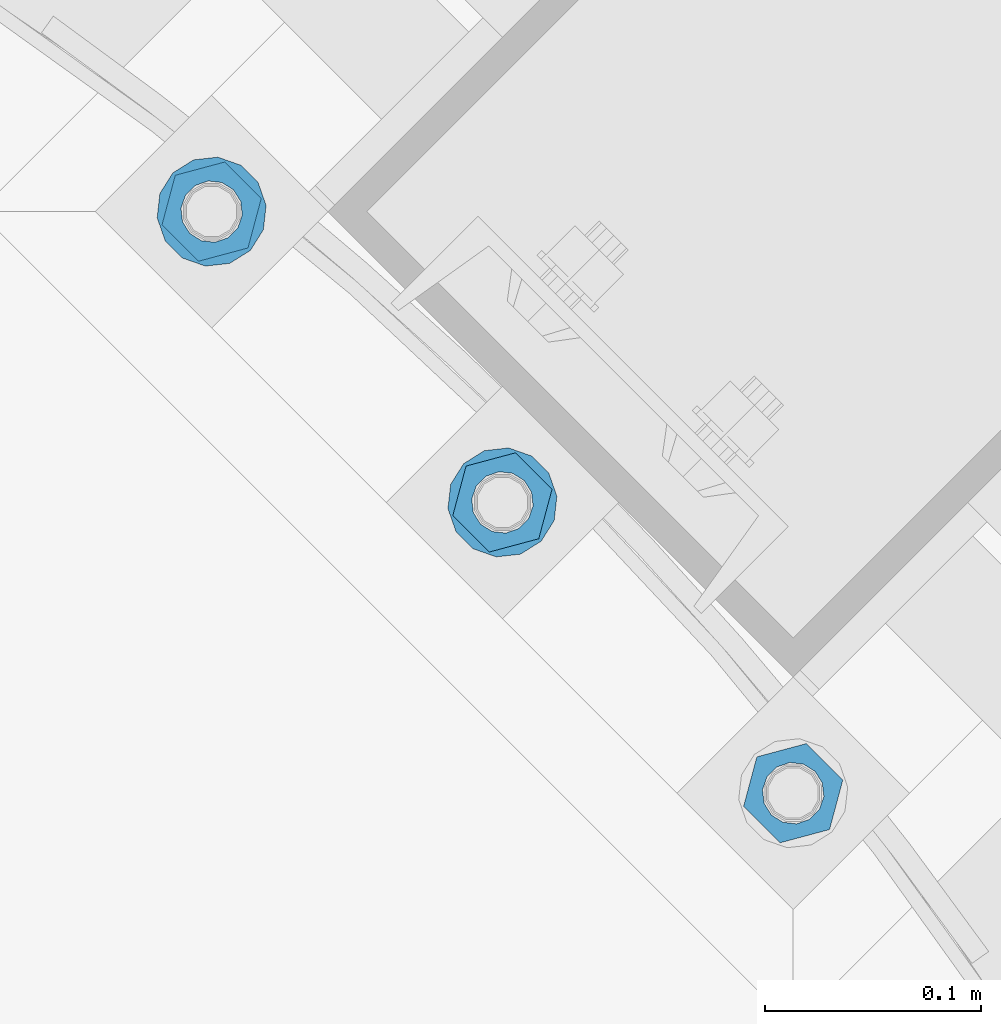
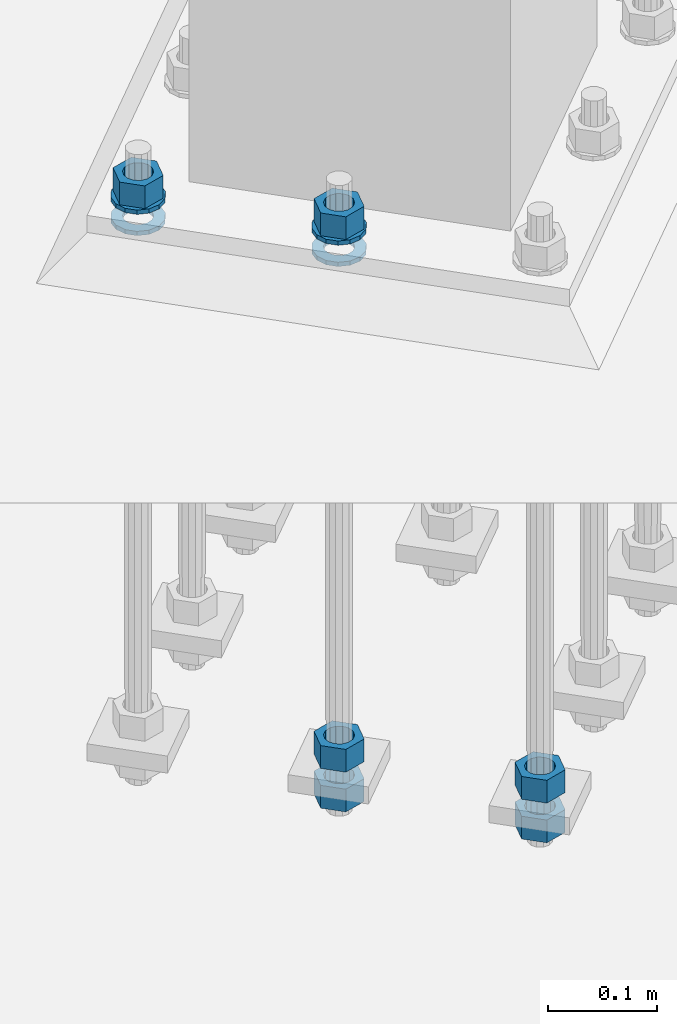
# One storey, part 874 of 1876: 10 columns, 1 element without a shape of its own.
"""IFC2X3 building model written with IfcOpenShell, lengths in millimetres."""

from ifc_helpers import new_model, si_unit, frame, origin_with_axes, place, context, subcontext, project, spatial, faceted_brep, material, type_object, element, aggregate, save


model = new_model("IFC2X3")

# Units and contexts
model_context = context("Model", 3, precision=1e-05, world=origin_with_axes())
body_context = subcontext(model_context, "Body", "Model", "MODEL_VIEW")
ifc_project = project(units=[si_unit("LENGTHUNIT", "METRE", prefix="MILLI"), si_unit("AREAUNIT", "SQUARE_METRE"), si_unit("VOLUMEUNIT", "CUBIC_METRE"), si_unit("MASSUNIT", "GRAM", prefix="KILO"), si_unit("TIMEUNIT", "SECOND"), si_unit("PLANEANGLEUNIT", "RADIAN"), si_unit("SOLIDANGLEUNIT", "STERADIAN"), si_unit("THERMODYNAMICTEMPERATUREUNIT", "DEGREE_CELSIUS"), si_unit("LUMINOUSINTENSITYUNIT", "LUMEN")], contexts=[model_context])

# Site, building, storey
site_placement = place(None, origin_with_axes())
site = spatial("IfcSite", under=ifc_project, at=site_placement, CompositionType="ELEMENT")
building_placement = place(site_placement, origin_with_axes())
building = spatial("IfcBuilding", under=site, at=building_placement, Name="Undefined", CompositionType="ELEMENT")
storey_placement = place(building_placement, origin_with_axes())
storey = spatial("IfcBuildingStorey", under=building, at=storey_placement, Name="Undefined", CompositionType="ELEMENT", Elevation=0.0)

# Assembly, columns
assembly_placement = place(storey_placement, origin_with_axes())
assembly = element("IfcElementAssembly", 1, at=assembly_placement, inside=storey, Name="TEMPLATE", AssemblyPlace="NOTDEFINED", PredefinedType="RIGID_FRAME")
ifc_material_1 = material(Name="STEEL/A563")
column_type_1 = type_object("IfcColumnType", Name="1_HEAVY_HEX_NUT", PredefinedType="NOTDEFINED")
column_1_placement = place(assembly_placement, frame((6580.27489085663, -12459.7327927759, -508.0), z_axis=(0.707106781186548, 0.707106781186547, 0.0), x_axis=(0.0, 0.0, -1.0)))
column_1 = element("IfcColumn", 2, at=column_1_placement, type_object=column_type_1, material=ifc_material_1, Name="NUT", ObjectType="1_HEAVY_HEX_NUT", context=body_context, shape_type="Brep", body=[
    faceted_brep([(0.0, -23.8099994659442, 9.09494701772928e-13), (0.0, -11.9099998474121, -20.6200008392352), (25.4, -11.9099998474157, -20.6200008392361), (25.4, -23.8099994659478, 0.0), (0.0, 11.9099998474157, -20.620000839237), (25.4, 11.9099998474121, -20.620000839237), (0.0, 23.8099994659478, 9.09494701772928e-13), (25.4, 23.8099994659442, 0.0), (0.0, 11.9099998474157, 20.620000839237), (25.4, 11.9099998474121, 20.620000839237), (0.0, -11.9099998474121, 20.6200008392389), (25.4, -11.9099998474157, 20.6200008392379), (0.0, 1.81898940354586e-12, 14.2899999618567), (0.0, 6.20019861543915, 12.8748450879584), (25.4, 6.20019861543733, 12.8748450879593), (25.4, 0.0, 14.2899999618558), (0.0, 11.1723718546473, 8.90966924477925), (25.4, 11.1723718546436, 8.90966924477925), (0.0, 13.9317198278914, 3.17982413774916), (25.4, 13.9317198278877, 3.17982413775007), (0.0, 13.9317198278914, -3.17982413774644), (25.4, 13.9317198278895, -3.17982413774735), (0.0, 11.1723718546473, -8.90966924477834), (25.4, 11.1723718546455, -8.90966924477925), (0.0, 6.20019861544279, -12.8748450879575), (25.4, 6.20019861543915, -12.8748450879584), (0.0, 3.63797880709171e-12, -14.2899999618548), (25.4, -3.63797880709171e-12, -14.2899999618548), (0.0, -6.20019861543733, -12.8748450879566), (25.4, -6.20019861544097, -12.8748450879584), (0.0, -11.1723718546455, -8.90966924477743), (25.4, -11.1723718546473, -8.90966924477834), (0.0, -13.9317198278877, -3.17982413774735), (25.4, -13.9317198278914, -3.17982413774826), (0.0, -13.9317198278895, 3.17982413774735), (25.4, -13.9317198278914, 3.17982413774826), (0.0, -11.1723718546455, 8.90966924477925), (25.4, -11.1723718546473, 8.90966924478016), (0.0, -6.20019861543915, 12.8748450879593), (25.4, -6.20019861544279, 12.8748450879593)], [[[0, 1, 2, 3]], [[1, 4, 5, 2]], [[4, 6, 7, 5]], [[6, 8, 9, 7]], [[8, 10, 11, 9]], [[10, 0, 3, 11]], [[12, 13, 14, 15]], [[13, 16, 17, 14]], [[16, 18, 19, 17]], [[18, 20, 21, 19]], [[20, 22, 23, 21]], [[22, 24, 25, 23]], [[24, 26, 27, 25]], [[26, 28, 29, 27]], [[28, 30, 31, 29]], [[30, 32, 33, 31]], [[32, 34, 35, 33]], [[34, 36, 37, 35]], [[36, 38, 39, 37]], [[38, 12, 15, 39]], [[5, 7, 9, 11, 3, 2], [17, 19, 21, 23, 25, 27, 29, 31, 33, 35, 37, 39, 15, 14]], [[10, 8, 6, 4, 1, 0], [38, 36, 34, 32, 30, 28, 26, 24, 22, 20, 18, 16, 13, 12]]]),
])
column_2_placement = place(assembly_placement, frame((6580.27489085663, -12459.7327927759, -552.45), z_axis=(0.707106781186548, 0.707106781186547, 0.0), x_axis=(0.0, 0.0, -1.0)))
column_2 = element("IfcColumn", 3, at=column_2_placement, type_object=column_type_1, material=ifc_material_1, Name="NUT", ObjectType="1_HEAVY_HEX_NUT", context=body_context, shape_type="Brep", body=[
    faceted_brep([(0.0, -23.8099994659442, 9.09494701772928e-13), (0.0, -11.9099998474121, -20.6200008392352), (25.4, -11.9099998474157, -20.6200008392361), (25.4, -23.8099994659478, 0.0), (0.0, 11.9099998474157, -20.620000839237), (25.4, 11.9099998474121, -20.620000839237), (0.0, 23.8099994659478, 9.09494701772928e-13), (25.4, 23.8099994659442, 0.0), (0.0, 11.9099998474157, 20.620000839237), (25.4, 11.9099998474121, 20.620000839237), (0.0, -11.9099998474121, 20.6200008392389), (25.4, -11.9099998474157, 20.6200008392379), (0.0, 1.81898940354586e-12, 14.2899999618567), (0.0, 6.20019861543915, 12.8748450879584), (25.4, 6.20019861543733, 12.8748450879593), (25.4, 0.0, 14.2899999618558), (0.0, 11.1723718546473, 8.90966924477925), (25.4, 11.1723718546436, 8.90966924477925), (0.0, 13.9317198278914, 3.17982413774916), (25.4, 13.9317198278877, 3.17982413775007), (0.0, 13.9317198278914, -3.17982413774644), (25.4, 13.9317198278895, -3.17982413774735), (0.0, 11.1723718546473, -8.90966924477834), (25.4, 11.1723718546455, -8.90966924477925), (0.0, 6.20019861544279, -12.8748450879575), (25.4, 6.20019861543915, -12.8748450879584), (0.0, 3.63797880709171e-12, -14.2899999618548), (25.4, -3.63797880709171e-12, -14.2899999618548), (0.0, -6.20019861543733, -12.8748450879566), (25.4, -6.20019861544097, -12.8748450879584), (0.0, -11.1723718546455, -8.90966924477743), (25.4, -11.1723718546473, -8.90966924477834), (0.0, -13.9317198278877, -3.17982413774735), (25.4, -13.9317198278914, -3.17982413774826), (0.0, -13.9317198278895, 3.17982413774735), (25.4, -13.9317198278914, 3.17982413774826), (0.0, -11.1723718546455, 8.90966924477925), (25.4, -11.1723718546473, 8.90966924478016), (0.0, -6.20019861543915, 12.8748450879593), (25.4, -6.20019861544279, 12.8748450879593)], [[[0, 1, 2, 3]], [[1, 4, 5, 2]], [[4, 6, 7, 5]], [[6, 8, 9, 7]], [[8, 10, 11, 9]], [[10, 0, 3, 11]], [[12, 13, 14, 15]], [[13, 16, 17, 14]], [[16, 18, 19, 17]], [[18, 20, 21, 19]], [[20, 22, 23, 21]], [[22, 24, 25, 23]], [[24, 26, 27, 25]], [[26, 28, 29, 27]], [[28, 30, 31, 29]], [[30, 32, 33, 31]], [[32, 34, 35, 33]], [[34, 36, 37, 35]], [[36, 38, 39, 37]], [[38, 12, 15, 39]], [[5, 7, 9, 11, 3, 2], [17, 19, 21, 23, 25, 27, 29, 31, 33, 35, 37, 39, 15, 14]], [[10, 8, 6, 4, 1, 0], [38, 36, 34, 32, 30, 28, 26, 24, 22, 20, 18, 16, 13, 12]]]),
])
column_3_placement = place(assembly_placement, frame((6445.57104904047, -12325.0289509597, 87.3125), z_axis=(0.707106781186548, 0.707106781186547, 0.0), x_axis=(0.0, 0.0, -1.0)))
column_3 = element("IfcColumn", 4, at=column_3_placement, type_object=column_type_1, material=ifc_material_1, Name="NUT", ObjectType="1_HEAVY_HEX_NUT", context=body_context, shape_type="Brep", body=[
    faceted_brep([(0.0, -23.8099994659442, 9.09494701772928e-13), (0.0, -11.9099998474121, -20.6200008392352), (25.4, -11.9099998474157, -20.6200008392361), (25.4, -23.8099994659478, 0.0), (0.0, 11.9099998474157, -20.620000839237), (25.4, 11.9099998474121, -20.620000839237), (0.0, 23.8099994659478, 9.09494701772928e-13), (25.4, 23.8099994659442, 0.0), (0.0, 11.9099998474157, 20.620000839237), (25.4, 11.9099998474121, 20.620000839237), (0.0, -11.9099998474121, 20.6200008392389), (25.4, -11.9099998474157, 20.6200008392379), (0.0, 1.81898940354586e-12, 14.2899999618567), (0.0, 6.20019861543915, 12.8748450879584), (25.4, 6.20019861543733, 12.8748450879593), (25.4, 0.0, 14.2899999618558), (0.0, 11.1723718546473, 8.90966924477925), (25.4, 11.1723718546436, 8.90966924477925), (0.0, 13.9317198278914, 3.17982413774916), (25.4, 13.9317198278877, 3.17982413775007), (0.0, 13.9317198278914, -3.17982413774644), (25.4, 13.9317198278895, -3.17982413774735), (0.0, 11.1723718546473, -8.90966924477834), (25.4, 11.1723718546455, -8.90966924477925), (0.0, 6.20019861544279, -12.8748450879575), (25.4, 6.20019861543915, -12.8748450879584), (0.0, 3.63797880709171e-12, -14.2899999618548), (25.4, -3.63797880709171e-12, -14.2899999618548), (0.0, -6.20019861543733, -12.8748450879566), (25.4, -6.20019861544097, -12.8748450879584), (0.0, -11.1723718546455, -8.90966924477743), (25.4, -11.1723718546473, -8.90966924477834), (0.0, -13.9317198278877, -3.17982413774735), (25.4, -13.9317198278914, -3.17982413774826), (0.0, -13.9317198278895, 3.17982413774735), (25.4, -13.9317198278914, 3.17982413774826), (0.0, -11.1723718546455, 8.90966924477925), (25.4, -11.1723718546473, 8.90966924478016), (0.0, -6.20019861543915, 12.8748450879593), (25.4, -6.20019861544279, 12.8748450879593)], [[[0, 1, 2, 3]], [[1, 4, 5, 2]], [[4, 6, 7, 5]], [[6, 8, 9, 7]], [[8, 10, 11, 9]], [[10, 0, 3, 11]], [[12, 13, 14, 15]], [[13, 16, 17, 14]], [[16, 18, 19, 17]], [[18, 20, 21, 19]], [[20, 22, 23, 21]], [[22, 24, 25, 23]], [[24, 26, 27, 25]], [[26, 28, 29, 27]], [[28, 30, 31, 29]], [[30, 32, 33, 31]], [[32, 34, 35, 33]], [[34, 36, 37, 35]], [[36, 38, 39, 37]], [[38, 12, 15, 39]], [[5, 7, 9, 11, 3, 2], [17, 19, 21, 23, 25, 27, 29, 31, 33, 35, 37, 39, 15, 14]], [[10, 8, 6, 4, 1, 0], [38, 36, 34, 32, 30, 28, 26, 24, 22, 20, 18, 16, 13, 12]]]),
])
column_4_placement = place(assembly_placement, frame((6445.57104904047, -12325.0289509597, -508.0), z_axis=(0.707106781186548, 0.707106781186547, 0.0), x_axis=(0.0, 0.0, -1.0)))
column_4 = element("IfcColumn", 5, at=column_4_placement, type_object=column_type_1, material=ifc_material_1, Name="NUT", ObjectType="1_HEAVY_HEX_NUT", context=body_context, shape_type="Brep", body=[
    faceted_brep([(0.0, -23.8099994659442, 9.09494701772928e-13), (0.0, -11.9099998474121, -20.6200008392352), (25.4, -11.9099998474157, -20.6200008392361), (25.4, -23.8099994659478, 0.0), (0.0, 11.9099998474157, -20.620000839237), (25.4, 11.9099998474121, -20.620000839237), (0.0, 23.8099994659478, 9.09494701772928e-13), (25.4, 23.8099994659442, 0.0), (0.0, 11.9099998474157, 20.620000839237), (25.4, 11.9099998474121, 20.620000839237), (0.0, -11.9099998474121, 20.6200008392389), (25.4, -11.9099998474157, 20.6200008392379), (0.0, 1.81898940354586e-12, 14.2899999618567), (0.0, 6.20019861543915, 12.8748450879584), (25.4, 6.20019861543733, 12.8748450879593), (25.4, 0.0, 14.2899999618558), (0.0, 11.1723718546473, 8.90966924477925), (25.4, 11.1723718546436, 8.90966924477925), (0.0, 13.9317198278914, 3.17982413774916), (25.4, 13.9317198278877, 3.17982413775007), (0.0, 13.9317198278914, -3.17982413774644), (25.4, 13.9317198278895, -3.17982413774735), (0.0, 11.1723718546473, -8.90966924477834), (25.4, 11.1723718546455, -8.90966924477925), (0.0, 6.20019861544279, -12.8748450879575), (25.4, 6.20019861543915, -12.8748450879584), (0.0, 3.63797880709171e-12, -14.2899999618548), (25.4, -3.63797880709171e-12, -14.2899999618548), (0.0, -6.20019861543733, -12.8748450879566), (25.4, -6.20019861544097, -12.8748450879584), (0.0, -11.1723718546455, -8.90966924477743), (25.4, -11.1723718546473, -8.90966924477834), (0.0, -13.9317198278877, -3.17982413774735), (25.4, -13.9317198278914, -3.17982413774826), (0.0, -13.9317198278895, 3.17982413774735), (25.4, -13.9317198278914, 3.17982413774826), (0.0, -11.1723718546455, 8.90966924477925), (25.4, -11.1723718546473, 8.90966924478016), (0.0, -6.20019861543915, 12.8748450879593), (25.4, -6.20019861544279, 12.8748450879593)], [[[0, 1, 2, 3]], [[1, 4, 5, 2]], [[4, 6, 7, 5]], [[6, 8, 9, 7]], [[8, 10, 11, 9]], [[10, 0, 3, 11]], [[12, 13, 14, 15]], [[13, 16, 17, 14]], [[16, 18, 19, 17]], [[18, 20, 21, 19]], [[20, 22, 23, 21]], [[22, 24, 25, 23]], [[24, 26, 27, 25]], [[26, 28, 29, 27]], [[28, 30, 31, 29]], [[30, 32, 33, 31]], [[32, 34, 35, 33]], [[34, 36, 37, 35]], [[36, 38, 39, 37]], [[38, 12, 15, 39]], [[5, 7, 9, 11, 3, 2], [17, 19, 21, 23, 25, 27, 29, 31, 33, 35, 37, 39, 15, 14]], [[10, 8, 6, 4, 1, 0], [38, 36, 34, 32, 30, 28, 26, 24, 22, 20, 18, 16, 13, 12]]]),
])
column_5_placement = place(assembly_placement, frame((6445.57104904047, -12325.0289509597, -552.45), z_axis=(0.707106781186548, 0.707106781186547, 0.0), x_axis=(0.0, 0.0, -1.0)))
column_5 = element("IfcColumn", 6, at=column_5_placement, type_object=column_type_1, material=ifc_material_1, Name="NUT", ObjectType="1_HEAVY_HEX_NUT", context=body_context, shape_type="Brep", body=[
    faceted_brep([(0.0, -23.8099994659442, 9.09494701772928e-13), (0.0, -11.9099998474121, -20.6200008392352), (25.4, -11.9099998474157, -20.6200008392361), (25.4, -23.8099994659478, 0.0), (0.0, 11.9099998474157, -20.620000839237), (25.4, 11.9099998474121, -20.620000839237), (0.0, 23.8099994659478, 9.09494701772928e-13), (25.4, 23.8099994659442, 0.0), (0.0, 11.9099998474157, 20.620000839237), (25.4, 11.9099998474121, 20.620000839237), (0.0, -11.9099998474121, 20.6200008392389), (25.4, -11.9099998474157, 20.6200008392379), (0.0, 1.81898940354586e-12, 14.2899999618567), (0.0, 6.20019861543915, 12.8748450879584), (25.4, 6.20019861543733, 12.8748450879593), (25.4, 0.0, 14.2899999618558), (0.0, 11.1723718546473, 8.90966924477925), (25.4, 11.1723718546436, 8.90966924477925), (0.0, 13.9317198278914, 3.17982413774916), (25.4, 13.9317198278877, 3.17982413775007), (0.0, 13.9317198278914, -3.17982413774644), (25.4, 13.9317198278895, -3.17982413774735), (0.0, 11.1723718546473, -8.90966924477834), (25.4, 11.1723718546455, -8.90966924477925), (0.0, 6.20019861544279, -12.8748450879575), (25.4, 6.20019861543915, -12.8748450879584), (0.0, 3.63797880709171e-12, -14.2899999618548), (25.4, -3.63797880709171e-12, -14.2899999618548), (0.0, -6.20019861543733, -12.8748450879566), (25.4, -6.20019861544097, -12.8748450879584), (0.0, -11.1723718546455, -8.90966924477743), (25.4, -11.1723718546473, -8.90966924477834), (0.0, -13.9317198278877, -3.17982413774735), (25.4, -13.9317198278914, -3.17982413774826), (0.0, -13.9317198278895, 3.17982413774735), (25.4, -13.9317198278914, 3.17982413774826), (0.0, -11.1723718546455, 8.90966924477925), (25.4, -11.1723718546473, 8.90966924478016), (0.0, -6.20019861543915, 12.8748450879593), (25.4, -6.20019861544279, 12.8748450879593)], [[[0, 1, 2, 3]], [[1, 4, 5, 2]], [[4, 6, 7, 5]], [[6, 8, 9, 7]], [[8, 10, 11, 9]], [[10, 0, 3, 11]], [[12, 13, 14, 15]], [[13, 16, 17, 14]], [[16, 18, 19, 17]], [[18, 20, 21, 19]], [[20, 22, 23, 21]], [[22, 24, 25, 23]], [[24, 26, 27, 25]], [[26, 28, 29, 27]], [[28, 30, 31, 29]], [[30, 32, 33, 31]], [[32, 34, 35, 33]], [[34, 36, 37, 35]], [[36, 38, 39, 37]], [[38, 12, 15, 39]], [[5, 7, 9, 11, 3, 2], [17, 19, 21, 23, 25, 27, 29, 31, 33, 35, 37, 39, 15, 14]], [[10, 8, 6, 4, 1, 0], [38, 36, 34, 32, 30, 28, 26, 24, 22, 20, 18, 16, 13, 12]]]),
])
column_6_placement = place(assembly_placement, frame((6310.86720722432, -12190.3251091436, 87.3125), z_axis=(-0.707106781186547, -0.707106781186548, 0.0), x_axis=(0.0, 0.0, -1.0)))
column_6 = element("IfcColumn", 7, at=column_6_placement, type_object=column_type_1, material=ifc_material_1, Name="NUT", ObjectType="1_HEAVY_HEX_NUT", context=body_context, shape_type="Brep", body=[
    faceted_brep([(0.0, -23.8099994659442, 9.09494701772928e-13), (0.0, -11.9099998474121, -20.6200008392352), (25.4, -11.9099998474157, -20.6200008392361), (25.4, -23.8099994659478, 0.0), (0.0, 11.9099998474157, -20.620000839237), (25.4, 11.9099998474121, -20.620000839237), (0.0, 23.8099994659478, 9.09494701772928e-13), (25.4, 23.8099994659442, 0.0), (0.0, 11.9099998474157, 20.620000839237), (25.4, 11.9099998474121, 20.620000839237), (0.0, -11.9099998474121, 20.6200008392389), (25.4, -11.9099998474157, 20.6200008392379), (0.0, 1.81898940354586e-12, 14.2899999618567), (0.0, 6.20019861543915, 12.8748450879584), (25.4, 6.20019861543733, 12.8748450879593), (25.4, 0.0, 14.2899999618558), (0.0, 11.1723718546473, 8.90966924477925), (25.4, 11.1723718546436, 8.90966924477925), (0.0, 13.9317198278914, 3.17982413774916), (25.4, 13.9317198278877, 3.17982413775007), (0.0, 13.9317198278914, -3.17982413774644), (25.4, 13.9317198278895, -3.17982413774735), (0.0, 11.1723718546473, -8.90966924477834), (25.4, 11.1723718546455, -8.90966924477925), (0.0, 6.20019861544279, -12.8748450879575), (25.4, 6.20019861543915, -12.8748450879584), (0.0, 3.63797880709171e-12, -14.2899999618548), (25.4, -3.63797880709171e-12, -14.2899999618548), (0.0, -6.20019861543733, -12.8748450879566), (25.4, -6.20019861544097, -12.8748450879584), (0.0, -11.1723718546455, -8.90966924477743), (25.4, -11.1723718546473, -8.90966924477834), (0.0, -13.9317198278877, -3.17982413774735), (25.4, -13.9317198278914, -3.17982413774826), (0.0, -13.9317198278895, 3.17982413774735), (25.4, -13.9317198278914, 3.17982413774826), (0.0, -11.1723718546455, 8.90966924477925), (25.4, -11.1723718546473, 8.90966924478016), (0.0, -6.20019861543915, 12.8748450879593), (25.4, -6.20019861544279, 12.8748450879593)], [[[0, 1, 2, 3]], [[1, 4, 5, 2]], [[4, 6, 7, 5]], [[6, 8, 9, 7]], [[8, 10, 11, 9]], [[10, 0, 3, 11]], [[12, 13, 14, 15]], [[13, 16, 17, 14]], [[16, 18, 19, 17]], [[18, 20, 21, 19]], [[20, 22, 23, 21]], [[22, 24, 25, 23]], [[24, 26, 27, 25]], [[26, 28, 29, 27]], [[28, 30, 31, 29]], [[30, 32, 33, 31]], [[32, 34, 35, 33]], [[34, 36, 37, 35]], [[36, 38, 39, 37]], [[38, 12, 15, 39]], [[5, 7, 9, 11, 3, 2], [17, 19, 21, 23, 25, 27, 29, 31, 33, 35, 37, 39, 15, 14]], [[10, 8, 6, 4, 1, 0], [38, 36, 34, 32, 30, 28, 26, 24, 22, 20, 18, 16, 13, 12]]]),
])
ifc_material_2 = material(Name="STEEL/F436")
column_type_2 = type_object("IfcColumnType", Name="1_WASHER", PredefinedType="NOTDEFINED")
column_7_placement = place(assembly_placement, frame((6445.57104904047, -12325.0289509597, 38.1), z_axis=(0.707106781186548, 0.707106781186547, 0.0), x_axis=(0.0, 0.0, -1.0)))
column_7 = element("IfcColumn", 8, at=column_7_placement, type_object=column_type_2, material=ifc_material_2, Name="WASHER", ObjectType="1_WASHER", context=body_context, shape_type="Brep", body=[
    faceted_brep([(0.0, -25.3999996185375, 0.0), (0.0, -22.8846089010331, -11.0206468080742), (4.7625, -22.8846089010331, -11.0206468080742), (4.7625, -25.3999996185375, 0.0), (0.0, -15.8366407293743, -19.8585193564477), (4.7625, -15.8366407293743, -19.8585193564477), (0.0, -5.65203163760816, -24.7631685975166), (4.7625, -5.65203163760816, -24.7631685975166), (0.0, 5.65203163760452, -24.7631685975166), (4.7625, 5.65203163760452, -24.7631685975166), (0.0, 15.8366407293706, -19.858519356445), (4.7625, 15.8366407293706, -19.858519356445), (0.0, 22.8846089010331, -11.0206468080733), (4.7625, 22.8846089010331, -11.0206468080733), (0.0, 25.3999996185339, 9.09494701772928e-13), (4.7625, 25.3999996185339, 9.09494701772928e-13), (0.0, 22.8846089010331, 11.0206468080751), (4.7625, 22.8846089010331, 11.0206468080751), (0.0, 15.8366407293706, 19.8585193564486), (4.7625, 15.8366407293706, 19.8585193564486), (0.0, 5.65203163760452, 24.7631685975175), (4.7625, 5.65203163760452, 24.7631685975175), (0.0, -5.65203163760816, 24.7631685975175), (4.7625, -5.65203163760816, 24.7631685975175), (0.0, -15.8366407293724, 19.8585193564459), (4.7625, -15.8366407293724, 19.8585193564459), (0.0, -22.8846089010367, 11.0206468080751), (4.7625, -22.8846089010367, 11.0206468080751), (0.0, 1.81898940354586e-12, 14.2899999618567), (0.0, 6.20019861543915, 12.8748450879584), (4.7625, 6.20019861543733, 12.8748450879593), (4.7625, 0.0, 14.2899999618558), (0.0, 11.1723718546473, 8.90966924477925), (4.7625, 11.1723718546436, 8.90966924477925), (0.0, 13.9317198278914, 3.17982413774916), (4.7625, 13.9317198278877, 3.17982413775007), (0.0, 13.9317198278914, -3.17982413774644), (4.7625, 13.9317198278895, -3.17982413774735), (0.0, 11.1723718546473, -8.90966924477834), (4.7625, 11.1723718546455, -8.90966924477925), (0.0, 6.20019861544279, -12.8748450879575), (4.7625, 6.20019861543915, -12.8748450879584), (0.0, 3.63797880709171e-12, -14.2899999618548), (4.7625, -3.63797880709171e-12, -14.2899999618548), (0.0, -6.20019861543733, -12.8748450879566), (4.7625, -6.20019861544097, -12.8748450879584), (0.0, -11.1723718546455, -8.90966924477743), (4.7625, -11.1723718546473, -8.90966924477834), (0.0, -13.9317198278877, -3.17982413774735), (4.7625, -13.9317198278914, -3.17982413774826), (0.0, -13.9317198278895, 3.17982413774735), (4.7625, -13.9317198278914, 3.17982413774826), (0.0, -11.1723718546455, 8.90966924477925), (4.7625, -11.1723718546473, 8.90966924478016), (0.0, -6.20019861543915, 12.8748450879593), (4.7625, -6.20019861544279, 12.8748450879593)], [[[0, 1, 2, 3]], [[1, 4, 5, 2]], [[4, 6, 7, 5]], [[6, 8, 9, 7]], [[8, 10, 11, 9]], [[10, 12, 13, 11]], [[12, 14, 15, 13]], [[14, 16, 17, 15]], [[16, 18, 19, 17]], [[18, 20, 21, 19]], [[20, 22, 23, 21]], [[22, 24, 25, 23]], [[24, 26, 27, 25]], [[26, 0, 3, 27]], [[28, 29, 30, 31]], [[29, 32, 33, 30]], [[32, 34, 35, 33]], [[34, 36, 37, 35]], [[36, 38, 39, 37]], [[38, 40, 41, 39]], [[40, 42, 43, 41]], [[42, 44, 45, 43]], [[44, 46, 47, 45]], [[46, 48, 49, 47]], [[48, 50, 51, 49]], [[50, 52, 53, 51]], [[52, 54, 55, 53]], [[54, 28, 31, 55]], [[5, 7, 9, 11, 13, 15, 17, 19, 21, 23, 25, 27, 3, 2], [33, 35, 37, 39, 41, 43, 45, 47, 49, 51, 53, 55, 31, 30]], [[26, 24, 22, 20, 18, 16, 14, 12, 10, 8, 6, 4, 1, 0], [54, 52, 50, 48, 46, 44, 42, 40, 38, 36, 34, 32, 29, 28]]]),
])
column_8_placement = place(assembly_placement, frame((6445.57104904047, -12325.0289509597, 61.9125), z_axis=(0.707106781186548, 0.707106781186547, 0.0), x_axis=(0.0, 0.0, -1.0)))
column_8 = element("IfcColumn", 9, at=column_8_placement, type_object=column_type_2, material=ifc_material_2, Name="WASHER", ObjectType="1_WASHER", context=body_context, shape_type="Brep", body=[
    faceted_brep([(0.0, -25.3999996185375, 0.0), (0.0, -22.8846089010331, -11.0206468080742), (4.7625, -22.8846089010331, -11.0206468080742), (4.7625, -25.3999996185375, 0.0), (0.0, -15.8366407293743, -19.8585193564477), (4.7625, -15.8366407293743, -19.8585193564477), (0.0, -5.65203163760816, -24.7631685975166), (4.7625, -5.65203163760816, -24.7631685975166), (0.0, 5.65203163760452, -24.7631685975166), (4.7625, 5.65203163760452, -24.7631685975166), (0.0, 15.8366407293706, -19.858519356445), (4.7625, 15.8366407293706, -19.858519356445), (0.0, 22.8846089010331, -11.0206468080733), (4.7625, 22.8846089010331, -11.0206468080733), (0.0, 25.3999996185339, 9.09494701772928e-13), (4.7625, 25.3999996185339, 9.09494701772928e-13), (0.0, 22.8846089010331, 11.0206468080751), (4.7625, 22.8846089010331, 11.0206468080751), (0.0, 15.8366407293706, 19.8585193564486), (4.7625, 15.8366407293706, 19.8585193564486), (0.0, 5.65203163760452, 24.7631685975175), (4.7625, 5.65203163760452, 24.7631685975175), (0.0, -5.65203163760816, 24.7631685975175), (4.7625, -5.65203163760816, 24.7631685975175), (0.0, -15.8366407293724, 19.8585193564459), (4.7625, -15.8366407293724, 19.8585193564459), (0.0, -22.8846089010367, 11.0206468080751), (4.7625, -22.8846089010367, 11.0206468080751), (0.0, 1.81898940354586e-12, 14.2899999618567), (0.0, 6.20019861543915, 12.8748450879584), (4.7625, 6.20019861543733, 12.8748450879593), (4.7625, 0.0, 14.2899999618558), (0.0, 11.1723718546473, 8.90966924477925), (4.7625, 11.1723718546436, 8.90966924477925), (0.0, 13.9317198278914, 3.17982413774916), (4.7625, 13.9317198278877, 3.17982413775007), (0.0, 13.9317198278914, -3.17982413774644), (4.7625, 13.9317198278895, -3.17982413774735), (0.0, 11.1723718546473, -8.90966924477834), (4.7625, 11.1723718546455, -8.90966924477925), (0.0, 6.20019861544279, -12.8748450879575), (4.7625, 6.20019861543915, -12.8748450879584), (0.0, 3.63797880709171e-12, -14.2899999618548), (4.7625, -3.63797880709171e-12, -14.2899999618548), (0.0, -6.20019861543733, -12.8748450879566), (4.7625, -6.20019861544097, -12.8748450879584), (0.0, -11.1723718546455, -8.90966924477743), (4.7625, -11.1723718546473, -8.90966924477834), (0.0, -13.9317198278877, -3.17982413774735), (4.7625, -13.9317198278914, -3.17982413774826), (0.0, -13.9317198278895, 3.17982413774735), (4.7625, -13.9317198278914, 3.17982413774826), (0.0, -11.1723718546455, 8.90966924477925), (4.7625, -11.1723718546473, 8.90966924478016), (0.0, -6.20019861543915, 12.8748450879593), (4.7625, -6.20019861544279, 12.8748450879593)], [[[0, 1, 2, 3]], [[1, 4, 5, 2]], [[4, 6, 7, 5]], [[6, 8, 9, 7]], [[8, 10, 11, 9]], [[10, 12, 13, 11]], [[12, 14, 15, 13]], [[14, 16, 17, 15]], [[16, 18, 19, 17]], [[18, 20, 21, 19]], [[20, 22, 23, 21]], [[22, 24, 25, 23]], [[24, 26, 27, 25]], [[26, 0, 3, 27]], [[28, 29, 30, 31]], [[29, 32, 33, 30]], [[32, 34, 35, 33]], [[34, 36, 37, 35]], [[36, 38, 39, 37]], [[38, 40, 41, 39]], [[40, 42, 43, 41]], [[42, 44, 45, 43]], [[44, 46, 47, 45]], [[46, 48, 49, 47]], [[48, 50, 51, 49]], [[50, 52, 53, 51]], [[52, 54, 55, 53]], [[54, 28, 31, 55]], [[5, 7, 9, 11, 13, 15, 17, 19, 21, 23, 25, 27, 3, 2], [33, 35, 37, 39, 41, 43, 45, 47, 49, 51, 53, 55, 31, 30]], [[26, 24, 22, 20, 18, 16, 14, 12, 10, 8, 6, 4, 1, 0], [54, 52, 50, 48, 46, 44, 42, 40, 38, 36, 34, 32, 29, 28]]]),
])
column_9_placement = place(assembly_placement, frame((6310.86720722432, -12190.3251091436, 38.1), z_axis=(-0.707106781186547, -0.707106781186548, 0.0), x_axis=(0.0, 0.0, -1.0)))
column_9 = element("IfcColumn", 10, at=column_9_placement, type_object=column_type_2, material=ifc_material_2, Name="WASHER", ObjectType="1_WASHER", context=body_context, shape_type="Brep", body=[
    faceted_brep([(0.0, -25.3999996185375, 0.0), (0.0, -22.8846089010331, -11.0206468080742), (4.7625, -22.8846089010331, -11.0206468080742), (4.7625, -25.3999996185375, 0.0), (0.0, -15.8366407293743, -19.8585193564477), (4.7625, -15.8366407293743, -19.8585193564477), (0.0, -5.65203163760816, -24.7631685975166), (4.7625, -5.65203163760816, -24.7631685975166), (0.0, 5.65203163760452, -24.7631685975166), (4.7625, 5.65203163760452, -24.7631685975166), (0.0, 15.8366407293706, -19.858519356445), (4.7625, 15.8366407293706, -19.858519356445), (0.0, 22.8846089010331, -11.0206468080733), (4.7625, 22.8846089010331, -11.0206468080733), (0.0, 25.3999996185339, 9.09494701772928e-13), (4.7625, 25.3999996185339, 9.09494701772928e-13), (0.0, 22.8846089010331, 11.0206468080751), (4.7625, 22.8846089010331, 11.0206468080751), (0.0, 15.8366407293706, 19.8585193564486), (4.7625, 15.8366407293706, 19.8585193564486), (0.0, 5.65203163760452, 24.7631685975175), (4.7625, 5.65203163760452, 24.7631685975175), (0.0, -5.65203163760816, 24.7631685975175), (4.7625, -5.65203163760816, 24.7631685975175), (0.0, -15.8366407293724, 19.8585193564459), (4.7625, -15.8366407293724, 19.8585193564459), (0.0, -22.8846089010367, 11.0206468080751), (4.7625, -22.8846089010367, 11.0206468080751), (0.0, 1.81898940354586e-12, 14.2899999618567), (0.0, 6.20019861543915, 12.8748450879584), (4.7625, 6.20019861543733, 12.8748450879593), (4.7625, 0.0, 14.2899999618558), (0.0, 11.1723718546473, 8.90966924477925), (4.7625, 11.1723718546436, 8.90966924477925), (0.0, 13.9317198278914, 3.17982413774916), (4.7625, 13.9317198278877, 3.17982413775007), (0.0, 13.9317198278914, -3.17982413774644), (4.7625, 13.9317198278895, -3.17982413774735), (0.0, 11.1723718546473, -8.90966924477834), (4.7625, 11.1723718546455, -8.90966924477925), (0.0, 6.20019861544279, -12.8748450879575), (4.7625, 6.20019861543915, -12.8748450879584), (0.0, 3.63797880709171e-12, -14.2899999618548), (4.7625, -3.63797880709171e-12, -14.2899999618548), (0.0, -6.20019861543733, -12.8748450879566), (4.7625, -6.20019861544097, -12.8748450879584), (0.0, -11.1723718546455, -8.90966924477743), (4.7625, -11.1723718546473, -8.90966924477834), (0.0, -13.9317198278877, -3.17982413774735), (4.7625, -13.9317198278914, -3.17982413774826), (0.0, -13.9317198278895, 3.17982413774735), (4.7625, -13.9317198278914, 3.17982413774826), (0.0, -11.1723718546455, 8.90966924477925), (4.7625, -11.1723718546473, 8.90966924478016), (0.0, -6.20019861543915, 12.8748450879593), (4.7625, -6.20019861544279, 12.8748450879593)], [[[0, 1, 2, 3]], [[1, 4, 5, 2]], [[4, 6, 7, 5]], [[6, 8, 9, 7]], [[8, 10, 11, 9]], [[10, 12, 13, 11]], [[12, 14, 15, 13]], [[14, 16, 17, 15]], [[16, 18, 19, 17]], [[18, 20, 21, 19]], [[20, 22, 23, 21]], [[22, 24, 25, 23]], [[24, 26, 27, 25]], [[26, 0, 3, 27]], [[28, 29, 30, 31]], [[29, 32, 33, 30]], [[32, 34, 35, 33]], [[34, 36, 37, 35]], [[36, 38, 39, 37]], [[38, 40, 41, 39]], [[40, 42, 43, 41]], [[42, 44, 45, 43]], [[44, 46, 47, 45]], [[46, 48, 49, 47]], [[48, 50, 51, 49]], [[50, 52, 53, 51]], [[52, 54, 55, 53]], [[54, 28, 31, 55]], [[5, 7, 9, 11, 13, 15, 17, 19, 21, 23, 25, 27, 3, 2], [33, 35, 37, 39, 41, 43, 45, 47, 49, 51, 53, 55, 31, 30]], [[26, 24, 22, 20, 18, 16, 14, 12, 10, 8, 6, 4, 1, 0], [54, 52, 50, 48, 46, 44, 42, 40, 38, 36, 34, 32, 29, 28]]]),
])
column_10_placement = place(assembly_placement, frame((6310.86720722432, -12190.3251091436, 61.9125), z_axis=(-0.707106781186547, -0.707106781186548, 0.0), x_axis=(0.0, 0.0, -1.0)))
column_10 = element("IfcColumn", 11, at=column_10_placement, type_object=column_type_2, material=ifc_material_2, Name="WASHER", ObjectType="1_WASHER", context=body_context, shape_type="Brep", body=[
    faceted_brep([(0.0, -25.3999996185375, 0.0), (0.0, -22.8846089010331, -11.0206468080742), (4.7625, -22.8846089010331, -11.0206468080742), (4.7625, -25.3999996185375, 0.0), (0.0, -15.8366407293743, -19.8585193564477), (4.7625, -15.8366407293743, -19.8585193564477), (0.0, -5.65203163760816, -24.7631685975166), (4.7625, -5.65203163760816, -24.7631685975166), (0.0, 5.65203163760452, -24.7631685975166), (4.7625, 5.65203163760452, -24.7631685975166), (0.0, 15.8366407293706, -19.858519356445), (4.7625, 15.8366407293706, -19.858519356445), (0.0, 22.8846089010331, -11.0206468080733), (4.7625, 22.8846089010331, -11.0206468080733), (0.0, 25.3999996185339, 9.09494701772928e-13), (4.7625, 25.3999996185339, 9.09494701772928e-13), (0.0, 22.8846089010331, 11.0206468080751), (4.7625, 22.8846089010331, 11.0206468080751), (0.0, 15.8366407293706, 19.8585193564486), (4.7625, 15.8366407293706, 19.8585193564486), (0.0, 5.65203163760452, 24.7631685975175), (4.7625, 5.65203163760452, 24.7631685975175), (0.0, -5.65203163760816, 24.7631685975175), (4.7625, -5.65203163760816, 24.7631685975175), (0.0, -15.8366407293724, 19.8585193564459), (4.7625, -15.8366407293724, 19.8585193564459), (0.0, -22.8846089010367, 11.0206468080751), (4.7625, -22.8846089010367, 11.0206468080751), (0.0, 1.81898940354586e-12, 14.2899999618567), (0.0, 6.20019861543915, 12.8748450879584), (4.7625, 6.20019861543733, 12.8748450879593), (4.7625, 0.0, 14.2899999618558), (0.0, 11.1723718546473, 8.90966924477925), (4.7625, 11.1723718546436, 8.90966924477925), (0.0, 13.9317198278914, 3.17982413774916), (4.7625, 13.9317198278877, 3.17982413775007), (0.0, 13.9317198278914, -3.17982413774644), (4.7625, 13.9317198278895, -3.17982413774735), (0.0, 11.1723718546473, -8.90966924477834), (4.7625, 11.1723718546455, -8.90966924477925), (0.0, 6.20019861544279, -12.8748450879575), (4.7625, 6.20019861543915, -12.8748450879584), (0.0, 3.63797880709171e-12, -14.2899999618548), (4.7625, -3.63797880709171e-12, -14.2899999618548), (0.0, -6.20019861543733, -12.8748450879566), (4.7625, -6.20019861544097, -12.8748450879584), (0.0, -11.1723718546455, -8.90966924477743), (4.7625, -11.1723718546473, -8.90966924477834), (0.0, -13.9317198278877, -3.17982413774735), (4.7625, -13.9317198278914, -3.17982413774826), (0.0, -13.9317198278895, 3.17982413774735), (4.7625, -13.9317198278914, 3.17982413774826), (0.0, -11.1723718546455, 8.90966924477925), (4.7625, -11.1723718546473, 8.90966924478016), (0.0, -6.20019861543915, 12.8748450879593), (4.7625, -6.20019861544279, 12.8748450879593)], [[[0, 1, 2, 3]], [[1, 4, 5, 2]], [[4, 6, 7, 5]], [[6, 8, 9, 7]], [[8, 10, 11, 9]], [[10, 12, 13, 11]], [[12, 14, 15, 13]], [[14, 16, 17, 15]], [[16, 18, 19, 17]], [[18, 20, 21, 19]], [[20, 22, 23, 21]], [[22, 24, 25, 23]], [[24, 26, 27, 25]], [[26, 0, 3, 27]], [[28, 29, 30, 31]], [[29, 32, 33, 30]], [[32, 34, 35, 33]], [[34, 36, 37, 35]], [[36, 38, 39, 37]], [[38, 40, 41, 39]], [[40, 42, 43, 41]], [[42, 44, 45, 43]], [[44, 46, 47, 45]], [[46, 48, 49, 47]], [[48, 50, 51, 49]], [[50, 52, 53, 51]], [[52, 54, 55, 53]], [[54, 28, 31, 55]], [[5, 7, 9, 11, 13, 15, 17, 19, 21, 23, 25, 27, 3, 2], [33, 35, 37, 39, 41, 43, 45, 47, 49, 51, 53, 55, 31, 30]], [[26, 24, 22, 20, 18, 16, 14, 12, 10, 8, 6, 4, 1, 0], [54, 52, 50, 48, 46, 44, 42, 40, 38, 36, 34, 32, 29, 28]]]),
])
aggregate(assembly, [column_1, column_2, column_3, column_7, column_8, column_4, column_5, column_6, column_9, column_10])

save(model, "model.ifc")
